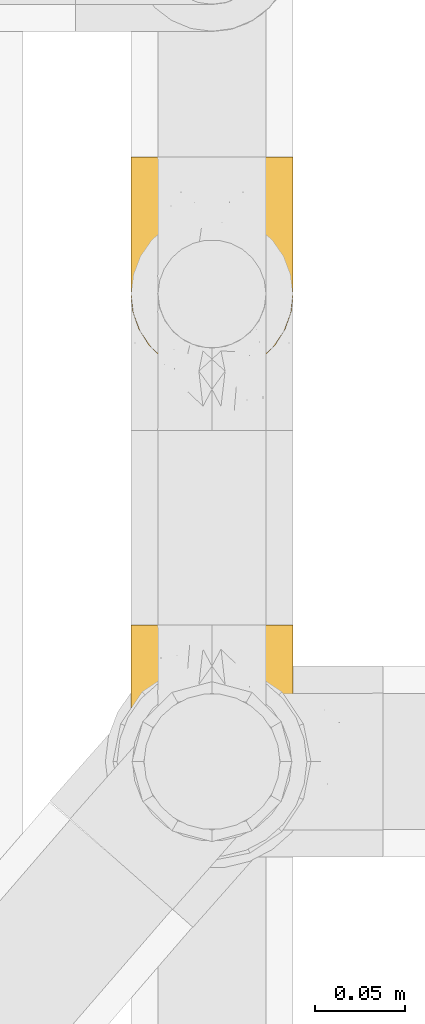
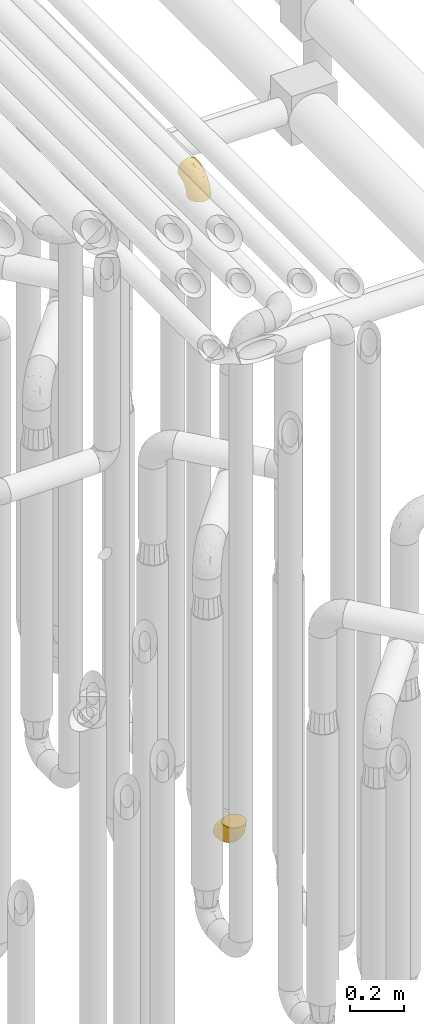
# One storey, part 218 of 827: 2 coverings.
"""IFC2X3 building model written with IfcOpenShell, lengths in millimetres."""

from ifc_helpers import new_model, entity, si_unit, converted_unit, derived_unit, direction, frame, origin, place, context, subcontext, project, spatial, faceted_brep, element, save


model = new_model("IFC2X3")

# Units and contexts
model_context = context("Model", 3, precision=0.01, world=origin(), true_north=direction((6.12303176911189e-17, 1.0)))
body_context = subcontext(model_context, "Body", "Model", "MODEL_VIEW")
ifc_project = project(units=[si_unit("LENGTHUNIT", "METRE", prefix="MILLI"), si_unit("AREAUNIT", "SQUARE_METRE"), si_unit("VOLUMEUNIT", "CUBIC_METRE"), converted_unit("PLANEANGLEUNIT", "DEGREE", entity("IfcRatioMeasure", 0.0174532925199433), si_unit("PLANEANGLEUNIT", "RADIAN"), dimensions=[0, 0, 0, 0, 0, 0, 0]), si_unit("MASSUNIT", "GRAM", prefix="KILO"), derived_unit("MASSDENSITYUNIT", [(si_unit("MASSUNIT", "GRAM", prefix="KILO"), 1), (si_unit("LENGTHUNIT", "METRE"), -3)]), derived_unit("MOMENTOFINERTIAUNIT", [(si_unit("LENGTHUNIT", "METRE"), 4)]), si_unit("TIMEUNIT", "SECOND"), si_unit("FREQUENCYUNIT", "HERTZ"), si_unit("THERMODYNAMICTEMPERATUREUNIT", "DEGREE_CELSIUS"), derived_unit("THERMALTRANSMITTANCEUNIT", [(si_unit("MASSUNIT", "GRAM", prefix="KILO"), 1), (si_unit("THERMODYNAMICTEMPERATUREUNIT", "KELVIN"), -1), (si_unit("TIMEUNIT", "SECOND"), -3)]), derived_unit("VOLUMETRICFLOWRATEUNIT", [(si_unit("LENGTHUNIT", "METRE"), 3), (si_unit("TIMEUNIT", "SECOND"), -1)]), derived_unit("MASSFLOWRATEUNIT", [(si_unit("MASSUNIT", "GRAM", prefix="KILO"), 1), (si_unit("TIMEUNIT", "SECOND"), -1)]), derived_unit("ROTATIONALFREQUENCYUNIT", [(si_unit("TIMEUNIT", "SECOND"), -1)]), si_unit("ELECTRICCURRENTUNIT", "AMPERE"), si_unit("ELECTRICVOLTAGEUNIT", "VOLT"), si_unit("POWERUNIT", "WATT"), si_unit("FORCEUNIT", "NEWTON", prefix="KILO"), si_unit("ILLUMINANCEUNIT", "LUX"), si_unit("LUMINOUSFLUXUNIT", "LUMEN"), si_unit("LUMINOUSINTENSITYUNIT", "CANDELA"), derived_unit("USERDEFINED", [(si_unit("MASSUNIT", "GRAM", prefix="KILO"), -1), (si_unit("LENGTHUNIT", "METRE"), -2), (si_unit("TIMEUNIT", "SECOND"), 3), (si_unit("LUMINOUSFLUXUNIT", "LUMEN"), 1)]), derived_unit("LINEARVELOCITYUNIT", [(si_unit("LENGTHUNIT", "METRE"), 1), (si_unit("TIMEUNIT", "SECOND"), -1)]), si_unit("PRESSUREUNIT", "PASCAL"), derived_unit("USERDEFINED", [(si_unit("LENGTHUNIT", "METRE"), -2), (si_unit("MASSUNIT", "GRAM", prefix="KILO"), 1), (si_unit("TIMEUNIT", "SECOND"), -2)]), derived_unit("LINEARFORCEUNIT", [(si_unit("MASSUNIT", "GRAM", prefix="KILO"), 1), (si_unit("LENGTHUNIT", "METRE"), 1), (si_unit("TIMEUNIT", "SECOND"), -2), (si_unit("LENGTHUNIT", "METRE"), -1)]), derived_unit("PLANARFORCEUNIT", [(si_unit("MASSUNIT", "GRAM", prefix="KILO"), 1), (si_unit("LENGTHUNIT", "METRE"), 1), (si_unit("TIMEUNIT", "SECOND"), -2), (si_unit("LENGTHUNIT", "METRE"), -2)])], contexts=[model_context])

# Site, building, storey
site_placement = place(None, origin())
site = spatial("IfcSite", under=ifc_project, at=site_placement, CompositionType="ELEMENT")
building_placement = place(site_placement, origin())
building = spatial("IfcBuilding", under=site, at=building_placement, CompositionType="ELEMENT")
storey_placement = place(building_placement, frame((0.0, 0.0, 28200.0)))
storey = spatial("IfcBuildingStorey", under=building, at=storey_placement, Name="08", CompositionType="ELEMENT", Elevation=28200.0)

# Coverings
covering_1_placement = place(storey_placement, frame((36928.29, 11683.46, 353.25)))
element("IfcCovering", 1, at=covering_1_placement, inside=storey, Name=":ADSK_", ObjectType=":ADSK_", PredefinedType="INSULATION", context=body_context, shape_type="Brep", body=[
    faceted_brep([(2.73, 36.69, 122.75), (6.07, 27.15, 122.75), (11.45, 18.59, 122.75), (18.6, 11.44, 122.75), (27.16, 6.06, 122.75), (36.7, 2.73, 122.75), (46.75, 1.6, 122.75), (56.8, 2.73, 122.75), (66.34, 6.07, 122.75), (74.9, 11.45, 122.75), (82.05, 18.6, 122.75), (87.43, 27.16, 122.75), (90.76, 36.7, 122.75), (91.9, 46.75, 122.75), (90.76, 56.8, 122.75), (87.42, 66.34, 122.75), (82.04, 74.9, 122.75), (74.89, 82.05, 122.75), (66.33, 87.43, 122.75), (56.79, 90.76, 122.75), (46.75, 91.9, 122.75), (36.69, 90.76, 122.75), (27.15, 87.42, 122.75), (18.59, 82.04, 122.75), (11.44, 74.89, 122.75), (6.06, 66.33, 122.75), (2.73, 56.79, 122.75), (1.6, 46.75, 122.75), (58.43, 122.75, 90.36), (69.32, 122.75, 85.85), (78.67, 122.75, 78.67), (85.85, 122.75, 69.32), (90.36, 122.75, 58.43), (91.9, 122.75, 46.75), (90.36, 122.75, 35.06), (85.85, 122.75, 24.17), (78.67, 122.75, 14.82), (69.32, 122.75, 7.64), (58.43, 122.75, 3.13), (46.75, 122.75, 1.6), (35.06, 122.75, 3.13), (24.17, 122.75, 7.64), (14.82, 122.75, 14.82), (7.64, 122.75, 24.17), (3.13, 122.75, 35.06), (1.6, 122.75, 46.75), (3.13, 122.75, 58.43), (7.64, 122.75, 69.32), (14.82, 122.75, 78.67), (24.17, 122.75, 85.85), (35.06, 122.75, 90.36), (46.75, 122.75, 91.9), (46.75, 24.73, 51.54), (38.29, 29.08, 47.17), (46.75, 38.13, 38.13), (46.75, 85.31, 7.52), (38.96, 93.59, 5.85), (46.75, 100.54, 5.11), (33.86, 63.54, 19.2), (31.42, 38.98, 38.98), (21.63, 50.71, 35.02), (30.84, 93.33, 8.21), (22.16, 75.2, 19.28), (20.56, 100.46, 12.19), (2.29, 41.6, 101.39), (7.18, 80.86, 34.43), (12.6, 94.87, 20.95), (14.0, 67.96, 30.74), (2.81, 52.16, 72.93), (6.65, 52.1, 56.64), (6.11, 36.74, 80.81), (16.62, 17.11, 93.43), (9.76, 23.24, 100.76), (12.46, 29.18, 74.27), (1.6, 52.53, 93.66), (1.6, 60.77, 81.33), (1.6, 69.01, 69.01), (2.46, 100.68, 40.87), (5.91, 103.79, 29.38), (36.97, 16.37, 67.05), (46.75, 7.52, 85.31), (33.09, 7.31, 93.68), (1.6, 93.66, 52.53), (1.6, 102.83, 50.71), (1.6, 112.01, 48.88), (25.62, 18.17, 72.77), (3.14, 71.97, 51.21), (23.92, 9.83, 101.18), (46.75, 5.11, 100.54), (13.58, 45.97, 48.74), (1.6, 48.88, 112.01), (1.6, 50.71, 102.83), (18.5, 22.83, 73.88), (46.75, 51.54, 24.73), (1.6, 81.33, 60.77), (4.96, 31.74, 103.08), (20.84, 32.48, 54.8), (46.75, 68.42, 16.13), (30.52, 25.33, 55.92), (46.75, 16.13, 68.42), (27.29, 92.29, 104.98), (36.89, 94.12, 108.58), (33.6, 100.97, 98.21), (2.54, 95.91, 61.56), (3.27, 107.9, 60.69), (16.85, 87.24, 100.0), (21.91, 95.46, 95.88), (13.5, 90.41, 90.81), (3.96, 74.17, 84.88), (3.52, 83.77, 73.29), (12.17, 76.72, 113.4), (18.93, 84.44, 109.8), (9.34, 76.42, 102.13), (3.12, 90.07, 67.29), (5.67, 99.69, 70.34), (2.51, 61.74, 95.15), (2.53, 58.16, 105.49), (8.35, 112.6, 71.5), (35.39, 110.45, 92.87), (46.75, 107.32, 96.03), (15.1, 108.48, 81.34), (5.27, 66.63, 107.44), (27.43, 115.23, 88.36), (24.89, 105.79, 90.43), (29.71, 89.6, 114.37), (5.07, 69.39, 98.41), (2.88, 66.99, 88.73), (9.69, 102.31, 76.89), (15.51, 99.54, 86.08), (2.27, 55.27, 112.64), (10.03, 82.03, 94.21), (46.75, 94.71, 112.22), (46.75, 96.03, 107.32), (8.83, 94.11, 79.95), (7.16, 84.21, 84.51), (46.75, 101.67, 101.67), (46.75, 112.22, 94.71), (78.39, 108.48, 81.34), (83.8, 102.31, 76.89), (77.97, 99.54, 86.08), (84.66, 94.11, 79.96), (58.1, 110.46, 92.87), (81.31, 76.74, 113.41), (91.9, 50.71, 102.83), (90.96, 58.17, 105.5), (91.22, 55.27, 112.64), (56.59, 94.12, 108.58), (66.18, 92.3, 104.98), (59.87, 100.98, 98.2), (88.42, 69.41, 98.4), (84.13, 76.44, 102.13), (88.22, 66.65, 107.44), (66.06, 115.24, 88.36), (91.9, 102.83, 50.71), (91.9, 112.01, 48.88), (83.44, 82.05, 94.22), (76.62, 87.25, 100.01), (85.14, 112.6, 71.5), (90.22, 107.9, 60.69), (91.9, 93.66, 52.53), (71.55, 95.48, 95.89), (63.77, 89.6, 114.37), (91.9, 60.77, 81.33), (91.9, 69.01, 69.01), (89.53, 74.17, 84.88), (91.9, 48.88, 112.01), (74.55, 84.45, 109.8), (90.95, 95.91, 61.56), (90.37, 90.07, 67.29), (91.9, 81.33, 60.77), (90.98, 61.75, 95.14), (89.97, 83.77, 73.29), (86.32, 84.21, 84.53), (91.9, 52.53, 93.66), (79.97, 90.42, 90.82), (90.61, 67.0, 88.73), (87.82, 99.69, 70.34), (68.6, 105.8, 90.43), (80.89, 94.87, 20.95), (86.31, 80.86, 34.43), (79.49, 67.95, 30.74), (71.33, 75.17, 19.29), (71.88, 50.65, 35.07), (90.35, 71.97, 51.21), (86.85, 52.08, 56.67), (72.67, 32.46, 54.85), (62.08, 38.98, 38.98), (87.58, 103.79, 29.38), (91.03, 100.68, 40.87), (59.62, 63.54, 19.2), (62.65, 93.32, 8.21), (54.53, 93.59, 5.85), (72.93, 100.44, 12.19), (90.68, 52.17, 72.93), (87.39, 36.75, 80.83), (91.2, 41.61, 101.39), (60.41, 7.31, 93.69), (76.88, 17.12, 93.43), (56.53, 16.37, 67.04), (83.74, 23.26, 100.76), (67.88, 18.17, 72.78), (62.99, 25.33, 55.93), (69.58, 9.84, 101.18), (81.04, 29.19, 74.27), (75.0, 22.84, 73.89), (88.53, 31.75, 103.09), (79.93, 45.96, 48.78), (55.21, 29.07, 47.19)], [[[0, 1, 2, 3, 4, 5, 6, 7, 8, 9, 10, 11, 12, 13, 14, 15, 16, 17, 18, 19, 20, 21, 22, 23, 24, 25, 26, 27]], [[28, 29, 30, 31, 32, 33, 34, 35, 36, 37, 38, 39, 40, 41, 42, 43, 44, 45, 46, 47, 48, 49, 50, 51]], [[52, 53, 54]], [[55, 56, 57]], [[58, 59, 60]], [[61, 62, 63]], [[27, 64, 0]], [[65, 66, 67]], [[41, 40, 61]], [[68, 69, 70]], [[66, 43, 42]], [[63, 42, 41]], [[71, 72, 73]], [[72, 2, 1]], [[68, 74, 75, 76]], [[45, 44, 77]], [[43, 78, 44]], [[79, 80, 81]], [[77, 82, 83, 84, 45]], [[79, 81, 85]], [[71, 2, 72]], [[65, 86, 77]], [[4, 81, 5]], [[66, 65, 78]], [[4, 3, 87]], [[81, 88, 5]], [[63, 66, 42]], [[68, 70, 64]], [[67, 60, 89]], [[71, 3, 2]], [[64, 27, 90, 91, 74]], [[92, 71, 73]], [[40, 57, 56]], [[59, 93, 54]], [[86, 76, 94, 82]], [[1, 0, 95]], [[58, 62, 61]], [[60, 96, 89]], [[85, 81, 87]], [[56, 97, 58]], [[65, 67, 69]], [[87, 81, 4]], [[67, 89, 69]], [[61, 63, 41]], [[95, 72, 1]], [[73, 72, 70]], [[69, 73, 70]], [[73, 89, 96]], [[3, 71, 87]], [[85, 87, 71]], [[58, 61, 56]], [[59, 58, 93]], [[76, 86, 68]], [[69, 89, 73]], [[68, 86, 69]], [[65, 69, 86]], [[68, 64, 74]], [[95, 64, 70]], [[98, 79, 85]], [[79, 52, 99, 80]], [[66, 62, 67]], [[62, 58, 60]], [[62, 60, 67]], [[59, 98, 96]], [[59, 96, 60]], [[96, 85, 92]], [[88, 81, 80]], [[88, 6, 5]], [[66, 63, 62]], [[64, 95, 0]], [[72, 95, 70]], [[77, 44, 78]], [[86, 82, 77]], [[40, 39, 57]], [[96, 98, 85]], [[40, 56, 61]], [[66, 78, 43]], [[77, 78, 65]], [[79, 98, 53]], [[96, 92, 73]], [[85, 71, 92]], [[97, 56, 55]], [[97, 93, 58]], [[53, 98, 59]], [[54, 53, 59]], [[79, 53, 52]], [[100, 101, 102]], [[46, 45, 84, 83]], [[103, 104, 82]], [[82, 104, 83]], [[105, 106, 107]], [[108, 109, 76]], [[110, 111, 112]], [[103, 113, 114]], [[115, 74, 116]], [[48, 47, 117]], [[118, 102, 119]], [[49, 48, 120]], [[74, 91, 116]], [[116, 121, 115]], [[49, 122, 50]], [[123, 106, 102]], [[124, 111, 22]], [[125, 126, 115]], [[23, 22, 111]], [[24, 110, 121]], [[120, 127, 128]], [[90, 26, 129]], [[27, 26, 90]], [[121, 125, 115]], [[24, 121, 25]], [[130, 105, 107]], [[129, 25, 116]], [[21, 20, 131]], [[120, 123, 122]], [[112, 105, 130]], [[50, 118, 51]], [[21, 124, 22]], [[101, 131, 132]], [[117, 120, 48]], [[24, 23, 110]], [[127, 114, 133]], [[75, 108, 76]], [[107, 134, 130]], [[133, 114, 113]], [[129, 116, 91]], [[25, 121, 116]], [[121, 112, 125]], [[75, 74, 115]], [[101, 135, 102]], [[131, 101, 21]], [[101, 100, 124]], [[128, 127, 133]], [[119, 136, 51, 118]], [[104, 47, 46]], [[83, 104, 46]], [[117, 104, 114]], [[101, 124, 21]], [[111, 124, 100]], [[102, 118, 123]], [[133, 134, 107]], [[111, 110, 23]], [[114, 104, 103]], [[94, 76, 109]], [[121, 110, 112]], [[122, 118, 50]], [[134, 109, 108]], [[133, 107, 128]], [[112, 108, 125]], [[126, 125, 108]], [[108, 75, 126]], [[75, 115, 126]], [[109, 134, 133]], [[130, 108, 112]], [[108, 130, 134]], [[105, 112, 111]], [[111, 100, 105]], [[106, 105, 100]], [[102, 106, 100]], [[128, 106, 123]], [[90, 129, 91]], [[25, 129, 26]], [[104, 117, 47]], [[117, 114, 127]], [[82, 94, 103]], [[113, 94, 109]], [[94, 113, 103]], [[133, 113, 109]], [[106, 128, 107]], [[123, 120, 128]], [[120, 122, 49]], [[118, 122, 123]], [[135, 101, 132]], [[135, 119, 102]], [[117, 127, 120]], [[30, 29, 137]], [[138, 139, 140]], [[51, 136, 119, 141]], [[142, 17, 16]], [[143, 144, 145]], [[146, 147, 148]], [[149, 150, 151]], [[152, 29, 28]], [[33, 32, 153, 154]], [[150, 155, 156]], [[157, 31, 30]], [[153, 158, 159]], [[29, 152, 137]], [[148, 141, 119]], [[156, 160, 147]], [[148, 135, 146]], [[137, 138, 157]], [[19, 161, 146]], [[162, 163, 164]], [[14, 13, 165]], [[153, 32, 158]], [[147, 161, 166]], [[18, 17, 166]], [[167, 168, 169]], [[166, 150, 156]], [[151, 150, 142]], [[151, 170, 149]], [[151, 16, 15]], [[171, 140, 172]], [[165, 143, 145]], [[173, 170, 144]], [[142, 166, 17]], [[19, 131, 20]], [[144, 170, 151]], [[18, 161, 19]], [[173, 144, 143]], [[140, 139, 174]], [[171, 164, 163]], [[164, 172, 155]], [[151, 15, 144]], [[145, 15, 14]], [[173, 162, 170]], [[149, 175, 164]], [[19, 146, 131]], [[132, 131, 146]], [[160, 148, 147]], [[159, 158, 167]], [[135, 132, 146]], [[158, 32, 31]], [[157, 158, 31]], [[167, 158, 176]], [[166, 161, 18]], [[146, 161, 147]], [[148, 177, 141]], [[171, 168, 140]], [[171, 163, 169]], [[151, 142, 16]], [[166, 142, 150]], [[152, 141, 177]], [[51, 141, 28]], [[138, 140, 176]], [[172, 140, 174]], [[175, 149, 170]], [[164, 150, 149]], [[170, 162, 175]], [[162, 164, 175]], [[155, 172, 174]], [[171, 172, 164]], [[155, 174, 156]], [[164, 155, 150]], [[160, 156, 174]], [[147, 166, 156]], [[139, 160, 174]], [[148, 160, 177]], [[15, 145, 144]], [[165, 145, 14]], [[137, 157, 30]], [[158, 157, 176]], [[168, 167, 176]], [[169, 159, 167]], [[140, 168, 176]], [[169, 168, 171]], [[137, 177, 139]], [[160, 139, 177]], [[141, 152, 28]], [[137, 152, 177]], [[148, 119, 135]], [[157, 138, 176]], [[139, 138, 137]], [[178, 179, 180]], [[181, 180, 182]], [[179, 183, 184]], [[185, 186, 182]], [[187, 188, 179]], [[188, 33, 154, 153, 159]], [[181, 189, 190]], [[35, 34, 187]], [[191, 38, 190]], [[192, 178, 181]], [[179, 184, 180]], [[192, 190, 37]], [[37, 190, 38]], [[36, 35, 178]], [[54, 93, 186]], [[35, 187, 178]], [[193, 194, 184]], [[195, 173, 143, 165, 13]], [[195, 193, 173]], [[193, 163, 162, 173]], [[13, 12, 195]], [[8, 7, 196]], [[9, 197, 10]], [[198, 80, 99, 52]], [[196, 7, 88]], [[197, 199, 10]], [[182, 189, 181]], [[200, 198, 201]], [[200, 196, 198]], [[9, 8, 202]], [[194, 199, 203]], [[192, 37, 36]], [[80, 196, 88]], [[183, 159, 169, 163]], [[188, 34, 33]], [[202, 200, 197]], [[185, 203, 204]], [[202, 8, 196]], [[10, 199, 11]], [[12, 11, 205]], [[38, 191, 57]], [[189, 97, 191]], [[203, 199, 197]], [[205, 199, 194]], [[204, 203, 197]], [[184, 203, 206]], [[200, 202, 196]], [[197, 9, 202]], [[207, 54, 186]], [[97, 55, 191]], [[194, 203, 184]], [[183, 163, 193]], [[184, 206, 180]], [[183, 193, 184]], [[205, 195, 12]], [[193, 195, 194]], [[80, 198, 196]], [[207, 186, 201]], [[182, 180, 206]], [[181, 178, 180]], [[185, 182, 206]], [[182, 186, 189]], [[203, 185, 206]], [[185, 200, 201]], [[7, 6, 88]], [[178, 192, 36]], [[190, 192, 181]], [[199, 205, 11]], [[195, 205, 194]], [[159, 183, 188]], [[179, 188, 183]], [[57, 191, 55]], [[57, 39, 38]], [[189, 191, 190]], [[188, 187, 34]], [[178, 187, 179]], [[186, 93, 189]], [[197, 200, 204]], [[185, 204, 200]], [[189, 93, 97]], [[207, 198, 52]], [[185, 201, 186]], [[198, 207, 201]], [[54, 207, 52]]]),
])
covering_2_placement = place(storey_placement, frame((36928.29, 11943.46, 3122.4)))
element("IfcCovering", 2, at=covering_2_placement, inside=storey, Name=":ADSK_", ObjectType=":ADSK_", PredefinedType="INSULATION", context=body_context, shape_type="Brep", body=[
    faceted_brep([(90.76, 36.69, 1.6), (87.42, 27.15, 1.6), (82.04, 18.59, 1.6), (74.89, 11.44, 1.6), (66.33, 6.06, 1.6), (56.79, 2.73, 1.6), (46.75, 1.6, 1.6), (36.69, 2.73, 1.6), (27.15, 6.07, 1.6), (18.59, 11.45, 1.6), (11.44, 18.6, 1.6), (6.06, 27.16, 1.6), (2.73, 36.7, 1.6), (1.6, 46.75, 1.6), (2.73, 56.8, 1.6), (6.07, 66.34, 1.6), (11.45, 74.9, 1.6), (18.6, 82.05, 1.6), (27.16, 87.43, 1.6), (36.7, 90.76, 1.6), (46.75, 91.9, 1.6), (56.8, 90.76, 1.6), (66.34, 87.42, 1.6), (74.9, 82.04, 1.6), (82.05, 74.89, 1.6), (87.43, 66.33, 1.6), (90.76, 56.79, 1.6), (91.9, 46.75, 1.6), (35.06, 122.75, 33.98), (24.17, 122.75, 38.49), (14.82, 122.75, 45.67), (7.64, 122.75, 55.02), (3.13, 122.75, 65.91), (1.6, 122.75, 77.6), (3.13, 122.75, 89.28), (7.64, 122.75, 100.17), (14.82, 122.75, 109.52), (24.17, 122.75, 116.7), (35.06, 122.75, 121.21), (46.75, 122.75, 122.75), (58.43, 122.75, 121.21), (69.32, 122.75, 116.7), (78.67, 122.75, 109.52), (85.85, 122.75, 100.17), (90.36, 122.75, 89.28), (91.9, 122.75, 77.6), (90.36, 122.75, 65.91), (85.85, 122.75, 55.02), (78.67, 122.75, 45.67), (69.32, 122.75, 38.49), (58.43, 122.75, 33.98), (46.75, 122.75, 32.45), (46.75, 24.73, 72.81), (55.2, 29.08, 77.17), (46.75, 38.13, 86.21), (46.75, 85.31, 116.82), (54.53, 93.59, 118.49), (46.75, 100.54, 119.23), (59.63, 63.54, 105.14), (62.07, 38.98, 85.37), (71.86, 50.71, 89.33), (62.65, 93.33, 116.14), (71.33, 75.2, 105.06), (72.93, 100.46, 112.15), (91.2, 41.6, 22.95), (86.31, 80.86, 89.91), (80.89, 94.87, 103.39), (79.49, 67.96, 93.6), (90.68, 52.16, 51.41), (86.84, 52.1, 67.71), (87.38, 36.74, 43.53), (76.87, 17.11, 30.91), (83.73, 23.24, 23.58), (81.03, 29.18, 50.07), (91.9, 52.53, 30.68), (91.9, 60.77, 43.01), (91.9, 69.01, 55.34), (91.03, 100.68, 83.48), (87.58, 103.79, 94.96), (56.52, 16.37, 57.29), (46.75, 7.52, 39.03), (60.4, 7.31, 30.66), (91.9, 93.66, 71.81), (91.9, 102.83, 73.63), (91.9, 112.01, 75.46), (67.87, 18.17, 51.57), (90.35, 71.97, 73.13), (69.57, 9.83, 23.16), (46.75, 5.11, 23.8), (79.91, 45.97, 75.6), (91.9, 48.88, 12.33), (91.9, 50.71, 21.51), (74.99, 22.83, 50.46), (46.75, 51.54, 99.61), (91.9, 81.33, 63.57), (88.53, 31.74, 21.26), (72.65, 32.48, 69.54), (46.75, 68.42, 108.21), (62.97, 25.33, 68.42), (46.75, 16.13, 55.92), (66.2, 92.29, 19.36), (56.6, 94.12, 15.76), (59.89, 100.97, 26.13), (90.95, 95.91, 62.78), (90.22, 107.9, 63.65), (76.64, 87.24, 24.34), (71.58, 95.46, 28.46), (79.99, 90.41, 33.53), (89.54, 74.17, 39.46), (89.97, 83.77, 51.05), (81.32, 76.72, 10.94), (74.56, 84.44, 14.55), (84.15, 76.42, 22.21), (90.37, 90.07, 57.05), (87.82, 99.69, 54.0), (90.98, 61.74, 29.19), (90.96, 58.16, 18.85), (85.14, 112.6, 52.84), (58.11, 110.45, 31.47), (46.75, 107.32, 28.31), (78.39, 108.48, 43.0), (88.22, 66.63, 16.9), (66.06, 115.23, 35.98), (68.6, 105.79, 33.91), (63.78, 89.6, 9.97), (88.42, 69.39, 25.93), (90.61, 66.99, 35.61), (83.8, 102.31, 47.45), (77.98, 99.54, 38.26), (91.22, 55.27, 11.7), (83.46, 82.03, 30.13), (46.75, 94.71, 12.12), (46.75, 96.03, 17.02), (84.66, 94.11, 44.39), (86.33, 84.21, 39.83), (46.75, 101.67, 22.67), (46.75, 112.22, 29.63), (15.1, 108.48, 43.0), (9.69, 102.31, 47.45), (15.52, 99.54, 38.26), (8.83, 94.11, 44.38), (35.39, 110.46, 31.47), (12.18, 76.74, 10.93), (1.6, 50.71, 21.51), (2.53, 58.17, 18.84), (2.27, 55.27, 11.7), (36.9, 94.12, 15.76), (27.31, 92.3, 19.36), (33.62, 100.98, 26.14), (5.07, 69.41, 25.94), (9.36, 76.44, 22.21), (5.27, 66.65, 16.9), (27.43, 115.24, 35.98), (1.6, 102.83, 73.63), (1.6, 112.01, 75.46), (10.05, 82.05, 30.12), (16.87, 87.25, 24.33), (8.35, 112.6, 52.84), (3.27, 107.9, 63.65), (1.6, 93.66, 71.81), (21.94, 95.48, 28.45), (29.72, 89.6, 9.97), (1.6, 60.77, 43.01), (1.6, 69.01, 55.34), (3.96, 74.17, 39.46), (1.6, 48.88, 12.33), (18.95, 84.45, 14.54), (2.54, 95.91, 62.78), (3.12, 90.07, 57.05), (1.6, 81.33, 63.57), (2.51, 61.75, 29.2), (3.52, 83.77, 51.05), (7.17, 84.21, 39.81), (1.6, 52.53, 30.68), (13.52, 90.42, 33.52), (2.88, 67.0, 35.61), (5.67, 99.69, 54.0), (24.89, 105.8, 33.91), (12.6, 94.87, 103.39), (7.18, 80.86, 89.91), (14.0, 67.95, 93.6), (22.16, 75.17, 105.05), (21.61, 50.65, 89.27), (3.14, 71.97, 73.13), (6.65, 52.08, 67.67), (20.82, 32.46, 69.49), (31.41, 38.98, 85.36), (5.91, 103.79, 94.96), (2.46, 100.68, 83.48), (33.87, 63.54, 105.14), (30.84, 93.32, 116.13), (38.96, 93.59, 118.49), (20.56, 100.44, 112.15), (2.81, 52.17, 51.41), (6.1, 36.75, 43.51), (2.29, 41.61, 22.95), (33.08, 7.31, 30.66), (16.61, 17.12, 30.91), (36.96, 16.37, 57.3), (9.75, 23.26, 23.58), (25.61, 18.17, 51.56), (30.5, 25.33, 68.41), (23.91, 9.84, 23.16), (12.45, 29.19, 50.07), (18.49, 22.84, 50.45), (4.96, 31.75, 21.25), (13.56, 45.96, 75.56), (38.28, 29.07, 77.16)], [[[0, 1, 2, 3, 4, 5, 6, 7, 8, 9, 10, 11, 12, 13, 14, 15, 16, 17, 18, 19, 20, 21, 22, 23, 24, 25, 26, 27]], [[28, 29, 30, 31, 32, 33, 34, 35, 36, 37, 38, 39, 40, 41, 42, 43, 44, 45, 46, 47, 48, 49, 50, 51]], [[52, 53, 54]], [[55, 56, 57]], [[58, 59, 60]], [[61, 62, 63]], [[27, 64, 0]], [[65, 66, 67]], [[41, 40, 61]], [[68, 69, 70]], [[66, 43, 42]], [[63, 42, 41]], [[71, 72, 73]], [[72, 2, 1]], [[68, 74, 75, 76]], [[45, 44, 77]], [[43, 78, 44]], [[79, 80, 81]], [[77, 82, 83, 84, 45]], [[79, 81, 85]], [[71, 2, 72]], [[65, 86, 77]], [[4, 81, 5]], [[66, 65, 78]], [[4, 3, 87]], [[81, 88, 5]], [[63, 66, 42]], [[68, 70, 64]], [[67, 60, 89]], [[71, 3, 2]], [[64, 27, 90, 91, 74]], [[92, 71, 73]], [[40, 57, 56]], [[59, 93, 54]], [[86, 76, 94, 82]], [[1, 0, 95]], [[58, 62, 61]], [[60, 96, 89]], [[85, 81, 87]], [[56, 97, 58]], [[65, 67, 69]], [[87, 81, 4]], [[67, 89, 69]], [[61, 63, 41]], [[95, 72, 1]], [[73, 72, 70]], [[69, 73, 70]], [[73, 89, 96]], [[3, 71, 87]], [[85, 87, 71]], [[58, 61, 56]], [[59, 58, 93]], [[76, 86, 68]], [[69, 89, 73]], [[68, 86, 69]], [[65, 69, 86]], [[68, 64, 74]], [[95, 64, 70]], [[98, 79, 85]], [[79, 52, 99, 80]], [[66, 62, 67]], [[62, 58, 60]], [[62, 60, 67]], [[59, 98, 96]], [[59, 96, 60]], [[96, 85, 92]], [[88, 81, 80]], [[88, 6, 5]], [[66, 63, 62]], [[64, 95, 0]], [[72, 95, 70]], [[77, 44, 78]], [[86, 82, 77]], [[40, 39, 57]], [[96, 98, 85]], [[40, 56, 61]], [[66, 78, 43]], [[77, 78, 65]], [[79, 98, 53]], [[96, 92, 73]], [[85, 71, 92]], [[97, 56, 55]], [[97, 93, 58]], [[53, 98, 59]], [[54, 53, 59]], [[79, 53, 52]], [[100, 101, 102]], [[46, 45, 84, 83]], [[103, 104, 82]], [[82, 104, 83]], [[105, 106, 107]], [[108, 109, 76]], [[110, 111, 112]], [[103, 113, 114]], [[115, 74, 116]], [[48, 47, 117]], [[118, 102, 119]], [[49, 48, 120]], [[74, 91, 116]], [[116, 121, 115]], [[49, 122, 50]], [[123, 106, 102]], [[124, 111, 22]], [[125, 126, 115]], [[23, 22, 111]], [[24, 110, 121]], [[120, 127, 128]], [[90, 26, 129]], [[27, 26, 90]], [[121, 125, 115]], [[24, 121, 25]], [[130, 105, 107]], [[129, 25, 116]], [[21, 20, 131]], [[120, 123, 122]], [[112, 105, 130]], [[50, 118, 51]], [[21, 124, 22]], [[101, 131, 132]], [[117, 120, 48]], [[24, 23, 110]], [[127, 114, 133]], [[75, 108, 76]], [[107, 134, 130]], [[133, 114, 113]], [[129, 116, 91]], [[25, 121, 116]], [[121, 112, 125]], [[75, 74, 115]], [[101, 135, 102]], [[131, 101, 21]], [[101, 100, 124]], [[128, 127, 133]], [[119, 136, 51, 118]], [[104, 47, 46]], [[83, 104, 46]], [[117, 104, 114]], [[101, 124, 21]], [[111, 124, 100]], [[102, 118, 123]], [[133, 134, 107]], [[111, 110, 23]], [[114, 104, 103]], [[94, 76, 109]], [[121, 110, 112]], [[122, 118, 50]], [[134, 109, 108]], [[133, 107, 128]], [[112, 108, 125]], [[126, 125, 108]], [[108, 75, 126]], [[75, 115, 126]], [[109, 134, 133]], [[130, 108, 112]], [[108, 130, 134]], [[105, 112, 111]], [[111, 100, 105]], [[106, 105, 100]], [[102, 106, 100]], [[128, 106, 123]], [[90, 129, 91]], [[25, 129, 26]], [[104, 117, 47]], [[117, 114, 127]], [[82, 94, 103]], [[113, 94, 109]], [[94, 113, 103]], [[133, 113, 109]], [[106, 128, 107]], [[123, 120, 128]], [[120, 122, 49]], [[118, 122, 123]], [[135, 101, 132]], [[135, 119, 102]], [[117, 127, 120]], [[30, 29, 137]], [[138, 139, 140]], [[51, 136, 119, 141]], [[142, 17, 16]], [[143, 144, 145]], [[146, 147, 148]], [[149, 150, 151]], [[152, 29, 28]], [[33, 32, 153, 154]], [[150, 155, 156]], [[157, 31, 30]], [[153, 158, 159]], [[29, 152, 137]], [[148, 141, 119]], [[156, 160, 147]], [[148, 135, 146]], [[137, 138, 157]], [[19, 161, 146]], [[162, 163, 164]], [[14, 13, 165]], [[153, 32, 158]], [[147, 161, 166]], [[18, 17, 166]], [[167, 168, 169]], [[166, 150, 156]], [[151, 150, 142]], [[151, 170, 149]], [[151, 16, 15]], [[171, 140, 172]], [[165, 143, 145]], [[173, 170, 144]], [[142, 166, 17]], [[19, 131, 20]], [[144, 170, 151]], [[18, 161, 19]], [[173, 144, 143]], [[140, 139, 174]], [[171, 164, 163]], [[164, 172, 155]], [[151, 15, 144]], [[145, 15, 14]], [[173, 162, 170]], [[149, 175, 164]], [[19, 146, 131]], [[132, 131, 146]], [[160, 148, 147]], [[159, 158, 167]], [[135, 132, 146]], [[158, 32, 31]], [[157, 158, 31]], [[167, 158, 176]], [[166, 161, 18]], [[146, 161, 147]], [[148, 177, 141]], [[171, 168, 140]], [[171, 163, 169]], [[151, 142, 16]], [[166, 142, 150]], [[152, 141, 177]], [[51, 141, 28]], [[138, 140, 176]], [[172, 140, 174]], [[175, 149, 170]], [[164, 150, 149]], [[170, 162, 175]], [[162, 164, 175]], [[155, 172, 174]], [[171, 172, 164]], [[155, 174, 156]], [[164, 155, 150]], [[160, 156, 174]], [[147, 166, 156]], [[139, 160, 174]], [[148, 160, 177]], [[15, 145, 144]], [[165, 145, 14]], [[137, 157, 30]], [[158, 157, 176]], [[168, 167, 176]], [[169, 159, 167]], [[140, 168, 176]], [[169, 168, 171]], [[137, 177, 139]], [[160, 139, 177]], [[141, 152, 28]], [[137, 152, 177]], [[148, 119, 135]], [[157, 138, 176]], [[139, 138, 137]], [[178, 179, 180]], [[181, 180, 182]], [[179, 183, 184]], [[185, 186, 182]], [[187, 188, 179]], [[188, 33, 154, 153, 159]], [[181, 189, 190]], [[35, 34, 187]], [[191, 38, 190]], [[192, 178, 181]], [[179, 184, 180]], [[192, 190, 37]], [[37, 190, 38]], [[36, 35, 178]], [[54, 93, 186]], [[35, 187, 178]], [[193, 194, 184]], [[195, 173, 143, 165, 13]], [[195, 193, 173]], [[193, 163, 162, 173]], [[13, 12, 195]], [[8, 7, 196]], [[9, 197, 10]], [[198, 80, 99, 52]], [[196, 7, 88]], [[197, 199, 10]], [[182, 189, 181]], [[200, 198, 201]], [[200, 196, 198]], [[9, 8, 202]], [[194, 199, 203]], [[192, 37, 36]], [[80, 196, 88]], [[183, 159, 169, 163]], [[188, 34, 33]], [[202, 200, 197]], [[185, 203, 204]], [[202, 8, 196]], [[10, 199, 11]], [[12, 11, 205]], [[38, 191, 57]], [[189, 97, 191]], [[203, 199, 197]], [[205, 199, 194]], [[204, 203, 197]], [[184, 203, 206]], [[200, 202, 196]], [[197, 9, 202]], [[207, 54, 186]], [[97, 55, 191]], [[194, 203, 184]], [[183, 163, 193]], [[184, 206, 180]], [[183, 193, 184]], [[205, 195, 12]], [[193, 195, 194]], [[80, 198, 196]], [[207, 186, 201]], [[182, 180, 206]], [[181, 178, 180]], [[185, 182, 206]], [[182, 186, 189]], [[203, 185, 206]], [[185, 200, 201]], [[7, 6, 88]], [[178, 192, 36]], [[190, 192, 181]], [[199, 205, 11]], [[195, 205, 194]], [[159, 183, 188]], [[179, 188, 183]], [[57, 191, 55]], [[57, 39, 38]], [[189, 191, 190]], [[188, 187, 34]], [[178, 187, 179]], [[186, 93, 189]], [[197, 200, 204]], [[185, 204, 200]], [[189, 93, 97]], [[207, 198, 52]], [[185, 201, 186]], [[198, 207, 201]], [[54, 207, 52]]]),
])

save(model, "model.ifc")
